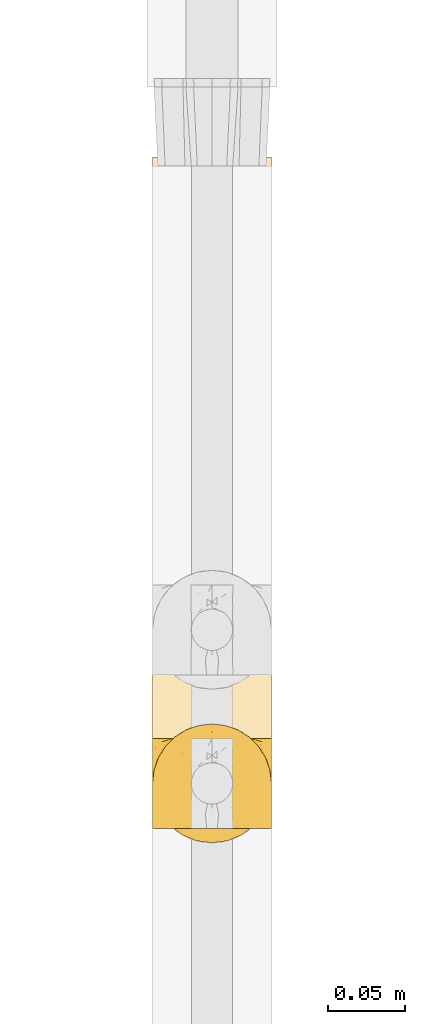
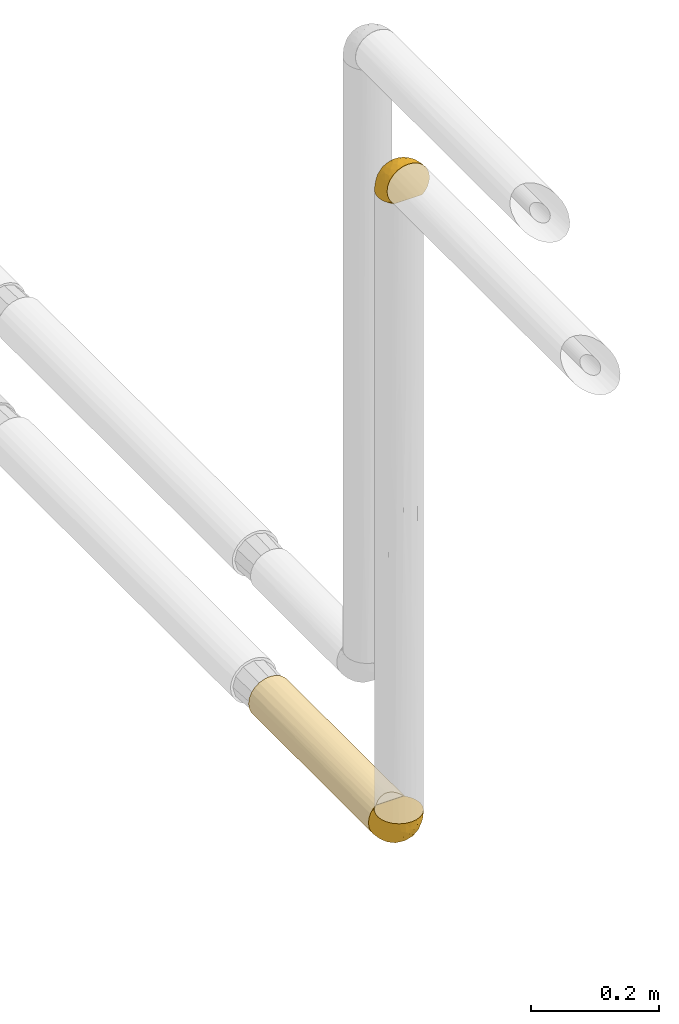
# One storey, part 105 of 827: 3 coverings.
"""IFC2X3 building model written with IfcOpenShell, lengths in millimetres."""

from ifc_helpers import new_model, entity, si_unit, converted_unit, derived_unit, direction, frame, origin, place, context, subcontext, project, spatial, faceted_brep, element, save


model = new_model("IFC2X3")

# Units and contexts
model_context = context("Model", 3, precision=0.01, world=origin(), true_north=direction((6.12303176911189e-17, 1.0)))
body_context = subcontext(model_context, "Body", "Model", "MODEL_VIEW")
ifc_project = project(units=[si_unit("LENGTHUNIT", "METRE", prefix="MILLI"), si_unit("AREAUNIT", "SQUARE_METRE"), si_unit("VOLUMEUNIT", "CUBIC_METRE"), converted_unit("PLANEANGLEUNIT", "DEGREE", entity("IfcRatioMeasure", 0.0174532925199433), si_unit("PLANEANGLEUNIT", "RADIAN"), dimensions=[0, 0, 0, 0, 0, 0, 0]), si_unit("MASSUNIT", "GRAM", prefix="KILO"), derived_unit("MASSDENSITYUNIT", [(si_unit("MASSUNIT", "GRAM", prefix="KILO"), 1), (si_unit("LENGTHUNIT", "METRE"), -3)]), derived_unit("MOMENTOFINERTIAUNIT", [(si_unit("LENGTHUNIT", "METRE"), 4)]), si_unit("TIMEUNIT", "SECOND"), si_unit("FREQUENCYUNIT", "HERTZ"), si_unit("THERMODYNAMICTEMPERATUREUNIT", "DEGREE_CELSIUS"), derived_unit("THERMALTRANSMITTANCEUNIT", [(si_unit("MASSUNIT", "GRAM", prefix="KILO"), 1), (si_unit("THERMODYNAMICTEMPERATUREUNIT", "KELVIN"), -1), (si_unit("TIMEUNIT", "SECOND"), -3)]), derived_unit("VOLUMETRICFLOWRATEUNIT", [(si_unit("LENGTHUNIT", "METRE"), 3), (si_unit("TIMEUNIT", "SECOND"), -1)]), derived_unit("MASSFLOWRATEUNIT", [(si_unit("MASSUNIT", "GRAM", prefix="KILO"), 1), (si_unit("TIMEUNIT", "SECOND"), -1)]), derived_unit("ROTATIONALFREQUENCYUNIT", [(si_unit("TIMEUNIT", "SECOND"), -1)]), si_unit("ELECTRICCURRENTUNIT", "AMPERE"), si_unit("ELECTRICVOLTAGEUNIT", "VOLT"), si_unit("POWERUNIT", "WATT"), si_unit("FORCEUNIT", "NEWTON", prefix="KILO"), si_unit("ILLUMINANCEUNIT", "LUX"), si_unit("LUMINOUSFLUXUNIT", "LUMEN"), si_unit("LUMINOUSINTENSITYUNIT", "CANDELA"), derived_unit("USERDEFINED", [(si_unit("MASSUNIT", "GRAM", prefix="KILO"), -1), (si_unit("LENGTHUNIT", "METRE"), -2), (si_unit("TIMEUNIT", "SECOND"), 3), (si_unit("LUMINOUSFLUXUNIT", "LUMEN"), 1)]), derived_unit("LINEARVELOCITYUNIT", [(si_unit("LENGTHUNIT", "METRE"), 1), (si_unit("TIMEUNIT", "SECOND"), -1)]), si_unit("PRESSUREUNIT", "PASCAL"), derived_unit("USERDEFINED", [(si_unit("LENGTHUNIT", "METRE"), -2), (si_unit("MASSUNIT", "GRAM", prefix="KILO"), 1), (si_unit("TIMEUNIT", "SECOND"), -2)]), derived_unit("LINEARFORCEUNIT", [(si_unit("MASSUNIT", "GRAM", prefix="KILO"), 1), (si_unit("LENGTHUNIT", "METRE"), 1), (si_unit("TIMEUNIT", "SECOND"), -2), (si_unit("LENGTHUNIT", "METRE"), -1)]), derived_unit("PLANARFORCEUNIT", [(si_unit("MASSUNIT", "GRAM", prefix="KILO"), 1), (si_unit("LENGTHUNIT", "METRE"), 1), (si_unit("TIMEUNIT", "SECOND"), -2), (si_unit("LENGTHUNIT", "METRE"), -2)])], contexts=[model_context])

# Site, building, storey
site_placement = place(None, origin())
site = spatial("IfcSite", under=ifc_project, at=site_placement, CompositionType="ELEMENT")
building_placement = place(site_placement, origin())
building = spatial("IfcBuilding", under=site, at=building_placement, CompositionType="ELEMENT")
storey_placement = place(building_placement, frame((0.0, 0.0, 28200.0)))
storey = spatial("IfcBuildingStorey", under=building, at=storey_placement, Name="08", CompositionType="ELEMENT", Elevation=28200.0)

# Coverings
covering_1_placement = place(storey_placement, frame((19736.22, 10277.55, 2771.03)))
element("IfcCovering", 1, at=covering_1_placement, inside=storey, Name=":ADSK_", ObjectType=":ADSK_", PredefinedType="INSULATION", context=body_context, shape_type="Brep", body=[
    faceted_brep([(5.41, 47.38, 1.6), (9.99, 54.67, 1.6), (16.08, 60.76, 1.6), (23.37, 65.34, 1.6), (31.49, 68.18, 1.6), (40.05, 69.15, 1.6), (48.61, 68.18, 1.6), (56.73, 65.33, 1.6), (64.02, 60.75, 1.6), (70.11, 54.66, 1.6), (74.69, 47.37, 1.6), (77.53, 39.25, 1.6), (78.5, 30.7, 1.6), (77.63, 22.59, 1.6), (75.08, 14.86, 1.6), (70.97, 7.84, 1.6), (65.47, 1.85, 1.6), (63.27, 1.85, 1.6), (61.53, 1.85, 1.6), (59.57, 1.85, 1.6), (57.6, 1.85, 1.6), (55.63, 1.85, 1.6), (53.67, 1.85, 1.6), (51.7, 1.85, 1.6), (49.73, 1.85, 1.6), (47.54, 1.85, 1.6), (45.34, 1.85, 1.6), (43.15, 1.85, 1.6), (40.96, 1.85, 1.6), (38.76, 1.85, 1.6), (36.57, 1.85, 1.6), (34.37, 1.85, 1.6), (32.18, 1.85, 1.6), (29.98, 1.85, 1.6), (27.79, 1.85, 1.6), (25.6, 1.85, 1.6), (23.4, 1.85, 1.6), (21.21, 1.85, 1.6), (19.01, 1.85, 1.6), (16.82, 1.85, 1.6), (14.62, 1.85, 1.6), (9.12, 7.85, 1.6), (5.0, 14.88, 1.6), (2.46, 22.61, 1.6), (1.6, 30.7, 1.6), (2.56, 39.26, 1.6), (65.47, 1.6, 1.85), (70.97, 1.6, 7.85), (75.09, 1.6, 14.87), (77.63, 1.6, 22.6), (78.5, 1.6, 30.7), (77.19, 1.6, 40.65), (73.34, 1.6, 49.92), (67.23, 1.6, 57.88), (59.27, 1.6, 63.99), (50.0, 1.6, 67.84), (40.05, 1.6, 69.15), (30.09, 1.6, 67.84), (20.82, 1.6, 63.99), (12.86, 1.6, 57.88), (6.75, 1.6, 49.92), (2.91, 1.6, 40.65), (1.6, 1.6, 30.7), (2.46, 1.6, 22.6), (5.0, 1.6, 14.87), (9.12, 1.6, 7.85), (14.62, 1.6, 1.85), (16.82, 1.6, 1.85), (17.8, 1.6, 1.85), (19.39, 1.6, 1.85), (20.98, 1.6, 1.85), (22.57, 1.6, 1.85), (24.16, 1.6, 1.85), (25.75, 1.6, 1.85), (27.33, 1.6, 1.85), (28.92, 1.6, 1.85), (30.51, 1.6, 1.85), (32.1, 1.6, 1.85), (33.69, 1.6, 1.85), (35.28, 1.6, 1.85), (36.87, 1.6, 1.85), (38.46, 1.6, 1.85), (40.05, 1.6, 1.85), (41.63, 1.6, 1.85), (43.22, 1.6, 1.85), (44.81, 1.6, 1.85), (46.4, 1.6, 1.85), (47.99, 1.6, 1.85), (49.58, 1.6, 1.85), (51.17, 1.6, 1.85), (52.76, 1.6, 1.85), (54.72, 1.6, 1.85), (56.69, 1.6, 1.85), (58.88, 1.6, 1.85), (61.08, 1.6, 1.85), (63.27, 1.6, 1.85), (37.77, 1.78, 1.77), (36.07, 1.77, 1.78), (32.96, 1.78, 1.77), (31.36, 1.77, 1.77), (56.52, 1.79, 1.76), (54.96, 1.78, 1.77), (18.75, 1.76, 1.79), (58.07, 1.77, 1.78), (50.37, 1.77, 1.78), (23.36, 1.76, 1.78), (24.95, 1.77, 1.78), (42.43, 1.77, 1.78), (15.97, 1.8, 1.74), (51.96, 1.76, 1.78), (53.47, 1.77, 1.78), (48.63, 1.78, 1.77), (63.93, 1.77, 1.78), (40.93, 1.77, 1.78), (29.72, 1.76, 1.78), (62.4, 1.77, 1.77), (60.92, 1.78, 1.77), (17.31, 1.77, 1.77), (21.74, 1.77, 1.78), (34.56, 1.77, 1.78), (20.18, 1.78, 1.77), (14.62, 1.77, 1.77), (14.62, 1.8, 1.72), (14.62, 1.82, 1.66), (65.47, 1.77, 1.77), (65.47, 1.72, 1.8), (65.47, 1.66, 1.82), (59.5, 1.76, 1.79), (47.1, 1.77, 1.78), (45.61, 1.76, 1.79), (28.18, 1.77, 1.78), (14.62, 1.66, 1.82), (14.62, 1.72, 1.8), (26.61, 1.78, 1.76), (65.47, 1.82, 1.66), (65.47, 1.8, 1.72), (39.32, 1.77, 1.78), (44.12, 1.78, 1.77), (72.26, 3.72, 9.41), (76.57, 7.41, 17.65), (71.77, 6.13, 7.41), (78.5, 21.47, 21.47), (77.9, 19.34, 15.21), (78.5, 26.8, 16.15), (78.5, 8.87, 28.75), (75.52, 9.2, 13.67), (76.13, 12.79, 12.79), (77.81, 14.62, 19.18), (78.5, 7.34, 29.16), (72.4, 5.33, 9.04), (76.56, 17.64, 7.41), (71.77, 7.7, 5.74), (72.25, 9.41, 3.72), (78.5, 28.75, 8.87), (78.5, 16.15, 26.8), (75.75, 14.14, 9.53), (78.5, 29.16, 7.34), (50.46, 57.02, 37.63), (52.75, 64.92, 17.92), (40.05, 64.0, 27.45), (77.7, 11.92, 37.01), (77.66, 19.16, 34.22), (71.02, 28.65, 45.87), (63.45, 24.62, 56.57), (70.55, 15.19, 52.31), (75.57, 18.36, 42.07), (75.57, 9.2, 44.74), (72.61, 46.98, 21.49), (72.61, 50.24, 11.02), (67.24, 56.1, 15.64), (77.74, 28.97, 26.02), (57.43, 54.46, 36.59), (47.19, 21.34, 65.49), (54.76, 18.4, 63.99), (40.05, 66.44, 15.2), (63.45, 12.07, 60.27), (60.1, 45.49, 45.25), (63.72, 50.57, 35.21), (76.83, 36.04, 22.52), (76.34, 42.07, 12.03), (60.51, 62.12, 13.32), (72.59, 37.37, 35.9), (76.05, 29.39, 33.87), (66.15, 53.59, 25.73), (60.51, 58.06, 26.34), (51.88, 49.27, 46.78), (55.34, 29.63, 59.54), (48.67, 33.21, 60.18), (53.89, 40.1, 53.93), (46.73, 44.08, 53.36), (40.05, 49.36, 49.36), (40.05, 56.68, 38.4), (40.05, 15.2, 66.44), (63.95, 35.57, 50.09), (67.24, 41.7, 41.08), (69.62, 46.4, 31.14), (73.6, 41.41, 28.19), (40.05, 27.45, 64.0), (40.05, 38.4, 56.68), (4.52, 12.99, 43.9), (32.72, 21.33, 65.46), (27.18, 42.89, 52.22), (29.63, 57.04, 37.61), (12.86, 56.11, 15.64), (19.59, 62.13, 13.31), (9.54, 21.89, 50.02), (16.64, 16.62, 59.28), (17.48, 32.9, 53.05), (7.49, 46.99, 21.48), (7.49, 50.25, 11.01), (3.75, 42.08, 12.03), (20.75, 49.91, 41.02), (2.33, 15.6, 35.39), (1.6, 16.15, 26.8), (1.6, 8.87, 28.75), (1.6, 29.16, 7.34), (26.94, 13.16, 65.81), (9.54, 10.83, 53.28), (31.21, 33.8, 59.8), (25.33, 25.02, 61.82), (27.35, 64.92, 17.91), (8.17, 32.83, 41.4), (4.3, 20.56, 40.48), (19.59, 58.07, 26.34), (2.23, 21.46, 31.68), (2.45, 28.1, 27.68), (1.6, 26.8, 16.15), (1.6, 21.47, 21.47), (12.86, 51.29, 28.05), (3.27, 36.04, 22.54), (1.6, 28.75, 8.87), (2.29, 8.45, 37.3), (12.86, 41.73, 41.07), (6.89, 39.27, 32.24), (12.43, 33.56, 47.4), (4.1, 27.29, 35.77), (3.53, 7.41, 17.65), (6.88, 3.51, 11.06), (8.16, 4.68, 8.55), (9.02, 5.52, 6.63), (5.0, 8.75, 12.77), (3.96, 12.79, 12.79), (3.52, 17.65, 7.41), (2.4, 13.9, 18.97), (7.83, 9.42, 3.72), (8.32, 7.68, 5.76), (2.19, 19.33, 15.21), (4.34, 14.13, 9.52)], [[[0, 1, 2, 3, 4, 5, 6, 7, 8, 9, 10, 11, 12, 13, 14, 15, 16, 17, 18, 19, 20, 21, 22, 23, 24, 25, 26, 27, 28, 29, 30, 31, 32, 33, 34, 35, 36, 37, 38, 39, 40, 41, 42, 43, 44, 45]], [[46, 47, 48, 49, 50, 51, 52, 53, 54, 55, 56, 57, 58, 59, 60, 61, 62, 63, 64, 65, 66, 67, 68, 69, 70, 71, 72, 73, 74, 75, 76, 77, 78, 79, 80, 81, 82, 83, 84, 85, 86, 87, 88, 89, 90, 91, 92, 93, 94, 95]], [[96, 97, 30]], [[98, 77, 99]], [[100, 101, 21]], [[69, 68, 102]], [[20, 19, 103]], [[24, 23, 104]], [[20, 103, 100]], [[72, 105, 106]], [[84, 83, 107]], [[89, 88, 104]], [[108, 67, 66]], [[109, 110, 90]], [[111, 25, 24]], [[112, 17, 16]], [[82, 113, 83]], [[109, 23, 22]], [[114, 76, 75]], [[105, 36, 106]], [[104, 111, 24]], [[18, 115, 116]], [[97, 96, 80]], [[67, 108, 117]], [[105, 71, 118]], [[31, 97, 119]], [[102, 120, 69]], [[108, 121, 122, 123, 40]], [[112, 95, 115]], [[17, 115, 18]], [[94, 116, 115]], [[117, 68, 67]], [[38, 117, 39]], [[112, 124, 125, 126, 46]], [[17, 112, 115]], [[70, 120, 118]], [[39, 117, 108]], [[120, 38, 37]], [[120, 37, 118]], [[120, 70, 69]], [[116, 94, 127]], [[128, 86, 129]], [[117, 38, 102]], [[74, 130, 75]], [[99, 33, 32]], [[115, 95, 94]], [[39, 108, 40]], [[108, 66, 131, 132, 121]], [[105, 72, 71]], [[118, 37, 36]], [[71, 70, 118]], [[35, 106, 36]], [[36, 105, 118]], [[35, 133, 106]], [[74, 73, 133]], [[106, 133, 73]], [[99, 114, 33]], [[133, 35, 34]], [[73, 72, 106]], [[95, 112, 46]], [[112, 16, 134, 135, 124]], [[130, 114, 75]], [[99, 76, 114]], [[114, 130, 33]], [[34, 33, 130]], [[78, 77, 98]], [[98, 119, 78]], [[130, 133, 34]], [[133, 130, 74]], [[79, 97, 80]], [[98, 99, 32]], [[98, 32, 31]], [[77, 76, 99]], [[97, 79, 119]], [[136, 96, 29]], [[30, 97, 31]], [[136, 29, 28]], [[81, 80, 96]], [[29, 96, 30]], [[31, 119, 98]], [[119, 79, 78]], [[96, 136, 81]], [[82, 81, 136]], [[113, 107, 83]], [[84, 107, 137]], [[107, 27, 137]], [[113, 28, 107]], [[27, 107, 28]], [[85, 84, 137]], [[137, 27, 26]], [[113, 136, 28]], [[136, 113, 82]], [[109, 89, 104]], [[86, 85, 129]], [[89, 109, 90]], [[111, 87, 128]], [[26, 129, 137]], [[88, 111, 104]], [[25, 111, 128]], [[22, 110, 109]], [[23, 109, 104]], [[110, 91, 90]], [[100, 92, 101]], [[110, 22, 101]], [[91, 110, 101]], [[116, 19, 18]], [[111, 88, 87]], [[127, 103, 19]], [[25, 128, 26]], [[86, 128, 87]], [[128, 129, 26]], [[137, 129, 85]], [[120, 102, 38]], [[117, 102, 68]], [[91, 101, 92]], [[21, 101, 22]], [[93, 92, 103]], [[100, 21, 20]], [[100, 103, 92]], [[127, 93, 103]], [[93, 127, 94]], [[116, 127, 19]], [[126, 138, 47]], [[48, 138, 139]], [[140, 125, 124]], [[141, 142, 143]], [[144, 49, 139]], [[145, 140, 146]], [[48, 139, 49]], [[139, 145, 147]], [[49, 144, 148, 50]], [[126, 125, 149]], [[14, 13, 150]], [[151, 146, 140]], [[149, 140, 145]], [[152, 151, 135]], [[152, 14, 150]], [[16, 15, 134]], [[13, 153, 150]], [[124, 151, 140]], [[141, 147, 142]], [[14, 152, 15]], [[15, 152, 134]], [[47, 46, 126]], [[139, 154, 144]], [[138, 48, 47]], [[125, 140, 149]], [[135, 134, 152]], [[146, 155, 142]], [[145, 146, 147]], [[149, 139, 138]], [[147, 141, 154]], [[147, 146, 142]], [[139, 147, 154]], [[139, 149, 145]], [[149, 138, 126]], [[155, 146, 151]], [[150, 143, 142]], [[152, 155, 151]], [[150, 142, 155]], [[13, 12, 156, 153]], [[153, 143, 150]], [[152, 150, 155]], [[151, 124, 135]], [[157, 158, 159]], [[160, 154, 161]], [[162, 163, 164]], [[165, 166, 160]], [[167, 168, 169]], [[141, 170, 161]], [[156, 12, 11]], [[158, 157, 171]], [[172, 55, 173]], [[158, 6, 174]], [[175, 54, 53]], [[52, 166, 164]], [[52, 164, 53]], [[54, 175, 173]], [[166, 52, 51]], [[176, 177, 171]], [[178, 143, 179]], [[156, 11, 179]], [[8, 7, 180]], [[169, 9, 8]], [[179, 143, 153, 156]], [[179, 11, 10]], [[168, 179, 10]], [[181, 162, 182]], [[179, 167, 178]], [[183, 184, 177]], [[183, 169, 184]], [[176, 171, 185]], [[172, 186, 187]], [[158, 7, 6]], [[159, 158, 174]], [[184, 180, 158]], [[54, 173, 55]], [[180, 169, 8]], [[188, 189, 187]], [[9, 168, 10]], [[186, 188, 187]], [[190, 157, 159, 191]], [[55, 172, 192]], [[176, 193, 194]], [[161, 170, 182]], [[162, 164, 165]], [[175, 164, 163]], [[51, 50, 148]], [[167, 195, 196]], [[178, 182, 170]], [[6, 5, 174]], [[158, 180, 7]], [[169, 180, 184]], [[169, 168, 9]], [[179, 168, 167]], [[182, 162, 165]], [[162, 194, 193]], [[161, 165, 160]], [[195, 181, 196]], [[192, 172, 197]], [[192, 56, 55]], [[189, 190, 198]], [[198, 197, 187]], [[172, 187, 197]], [[185, 189, 188]], [[198, 187, 189]], [[186, 172, 173]], [[173, 163, 186]], [[193, 186, 163]], [[176, 185, 188]], [[185, 157, 190]], [[188, 186, 193]], [[177, 176, 194]], [[188, 193, 176]], [[162, 193, 163]], [[195, 177, 194]], [[171, 177, 184]], [[181, 195, 194]], [[183, 167, 169]], [[162, 181, 194]], [[196, 182, 178]], [[158, 171, 184]], [[171, 157, 185]], [[177, 195, 183]], [[167, 183, 195]], [[182, 196, 181]], [[178, 170, 143]], [[178, 167, 196]], [[164, 175, 53]], [[173, 175, 163]], [[160, 51, 148]], [[164, 166, 165]], [[51, 160, 166]], [[160, 148, 144, 154]], [[141, 161, 154]], [[182, 165, 161]], [[190, 189, 185]], [[143, 170, 141]], [[60, 199, 61]], [[197, 200, 192]], [[201, 190, 202]], [[200, 57, 192]], [[203, 204, 2]], [[205, 206, 207]], [[208, 209, 210]], [[211, 207, 201]], [[212, 213, 214]], [[45, 215, 210]], [[216, 206, 58]], [[45, 44, 215]], [[59, 217, 60]], [[60, 217, 199]], [[0, 45, 210]], [[218, 201, 219]], [[202, 159, 220]], [[205, 221, 222]], [[223, 204, 203]], [[1, 203, 2]], [[57, 200, 216]], [[220, 3, 204]], [[220, 174, 4]], [[1, 0, 209]], [[212, 224, 213]], [[225, 226, 227]], [[228, 223, 203]], [[208, 210, 229]], [[210, 226, 229]], [[3, 220, 4]], [[58, 206, 59]], [[209, 203, 1]], [[202, 220, 223]], [[228, 203, 208]], [[202, 211, 201]], [[3, 2, 204]], [[202, 190, 191, 159]], [[210, 215, 230, 226]], [[199, 212, 231]], [[232, 233, 221]], [[233, 208, 229]], [[207, 206, 219]], [[217, 206, 205]], [[227, 224, 225]], [[233, 232, 228]], [[201, 207, 219]], [[234, 232, 221]], [[218, 219, 200]], [[202, 223, 211]], [[174, 220, 159]], [[174, 5, 4]], [[61, 231, 62]], [[220, 204, 223]], [[210, 209, 0]], [[203, 209, 208]], [[225, 233, 229]], [[224, 227, 213]], [[221, 233, 235]], [[57, 56, 192]], [[198, 218, 197]], [[200, 219, 216]], [[201, 198, 190]], [[197, 218, 200]], [[198, 201, 218]], [[206, 216, 219]], [[58, 57, 216]], [[231, 212, 214]], [[222, 212, 199]], [[228, 211, 223]], [[207, 211, 232]], [[62, 231, 214]], [[199, 231, 61]], [[233, 228, 208]], [[211, 228, 232]], [[222, 221, 235]], [[234, 205, 207]], [[206, 217, 59]], [[199, 217, 205]], [[205, 222, 199]], [[224, 222, 235]], [[222, 224, 212]], [[224, 235, 225]], [[233, 225, 235]], [[226, 225, 229]], [[205, 234, 221]], [[207, 232, 234]], [[63, 214, 236]], [[214, 213, 236]], [[214, 63, 62]], [[237, 236, 238]], [[238, 132, 131]], [[236, 237, 64]], [[239, 240, 241]], [[63, 236, 64]], [[131, 66, 65]], [[237, 131, 65]], [[242, 230, 43]], [[237, 65, 64]], [[239, 121, 132]], [[42, 242, 43]], [[241, 240, 243]], [[41, 123, 244]], [[43, 230, 215, 44]], [[244, 122, 245]], [[227, 246, 243]], [[241, 247, 245]], [[121, 239, 245]], [[41, 40, 123]], [[132, 238, 239]], [[244, 42, 41]], [[131, 237, 238]], [[240, 239, 238]], [[245, 239, 241]], [[247, 241, 246]], [[247, 244, 245]], [[238, 236, 240]], [[243, 236, 213]], [[236, 243, 240]], [[227, 226, 246]], [[243, 213, 227]], [[242, 246, 226]], [[243, 246, 241]], [[246, 242, 247]], [[244, 247, 242]], [[242, 226, 230]], [[42, 244, 242]], [[122, 244, 123]], [[122, 121, 245]]]),
])
covering_2_placement = place(storey_placement, frame((19736.27, 10335.75, 1518.17)))
element("IfcCovering", 2, at=covering_2_placement, inside=storey, Name=":ADSK_", ObjectType=":ADSK_", PredefinedType="INSULATION", context=body_context, shape_type="Brep", body=[
    faceted_brep([(20.8, 1.6, 6.74), (30.06, 1.6, 2.9), (40.0, 1.6, 1.6), (49.93, 1.6, 2.9), (59.2, 1.6, 6.74), (67.15, 1.6, 12.84), (73.25, 1.6, 20.8), (77.09, 1.6, 30.06), (78.4, 1.6, 40.0), (77.51, 1.6, 48.2), (74.9, 1.6, 56.01), (70.68, 1.6, 63.08), (65.05, 1.6, 69.1), (14.94, 1.6, 69.1), (9.31, 1.6, 63.08), (5.09, 1.6, 56.01), (2.48, 1.6, 48.2), (1.6, 1.6, 40.0), (2.9, 1.6, 30.06), (6.74, 1.6, 20.8), (12.84, 1.6, 12.84), (20.8, 377.5, 6.74), (12.84, 377.5, 12.84), (6.74, 377.5, 20.8), (2.9, 377.5, 30.06), (1.6, 377.5, 40.0), (2.9, 377.5, 49.93), (6.74, 377.5, 59.2), (12.84, 377.5, 67.15), (20.8, 377.5, 73.25), (30.06, 377.5, 77.09), (40.0, 377.5, 78.4), (49.93, 377.5, 77.09), (59.2, 377.5, 73.25), (67.15, 377.5, 67.15), (73.25, 377.5, 59.2), (77.09, 377.5, 49.93), (78.4, 377.5, 40.0), (77.09, 377.5, 30.06), (73.25, 377.5, 20.8), (67.15, 377.5, 12.84), (59.2, 377.5, 6.74), (49.93, 377.5, 2.9), (40.0, 377.5, 1.6), (30.06, 377.5, 2.9), (53.36, 8.5, 76.0), (46.78, 10.29, 77.79), (40.0, 10.9, 78.4), (59.51, 5.57, 73.07), (33.21, 10.29, 77.79), (26.63, 8.5, 76.0), (20.48, 5.57, 73.07)], [[[0, 1, 2, 3, 4, 5, 6, 7, 8, 9, 10, 11, 12, 13, 14, 15, 16, 17, 18, 19, 20]], [[21, 22, 23, 24, 25, 26, 27, 28, 29, 30, 31, 32, 33, 34, 35, 36, 37, 38, 39, 40, 41, 42, 43, 44]], [[24, 23, 19, 18]], [[25, 24, 18, 17]], [[20, 19, 23, 22]], [[1, 0, 21, 44]], [[2, 1, 44, 43]], [[22, 21, 0, 20]], [[3, 2, 43, 42]], [[4, 3, 42, 41]], [[41, 40, 5, 4]], [[7, 6, 39, 38]], [[8, 7, 38, 37]], [[40, 39, 6, 5]], [[9, 37, 36]], [[10, 36, 35]], [[11, 35, 34]], [[8, 37, 9]], [[9, 36, 10]], [[35, 11, 10]], [[34, 12, 11]], [[45, 33, 32]], [[32, 31, 46]], [[47, 46, 31]], [[48, 12, 33]], [[46, 45, 32]], [[48, 33, 45]], [[33, 12, 34]], [[49, 47, 31]], [[49, 31, 30]], [[50, 30, 29]], [[50, 49, 30]], [[13, 51, 29]], [[50, 29, 51]], [[29, 28, 13]], [[14, 28, 27]], [[15, 27, 26]], [[16, 26, 25]], [[14, 27, 15]], [[15, 26, 16]], [[25, 17, 16]], [[28, 14, 13]], [[48, 45, 46, 47, 49, 50, 51, 13, 12]]]),
])
covering_3_placement = place(storey_placement, frame((19736.22, 10268.2, 1518.12)))
element("IfcCovering", 3, at=covering_3_placement, inside=storey, Name=":ADSK_", ObjectType=":ADSK_", PredefinedType="INSULATION", context=body_context, shape_type="Brep", body=[
    faceted_brep([(74.68, 69.15, 23.36), (70.1, 69.15, 16.07), (64.01, 69.15, 9.98), (56.72, 69.15, 5.4), (48.6, 69.15, 2.56), (40.05, 69.15, 1.6), (31.49, 69.15, 2.56), (23.36, 69.15, 5.41), (16.07, 69.15, 9.99), (9.98, 69.15, 16.08), (5.4, 69.15, 23.37), (2.56, 69.15, 31.49), (1.6, 69.15, 40.05), (2.46, 69.15, 48.15), (5.01, 69.15, 55.88), (9.13, 69.15, 62.9), (14.62, 69.15, 68.89), (16.82, 69.15, 68.89), (18.56, 69.15, 68.89), (20.52, 69.15, 68.89), (22.49, 69.15, 68.89), (24.46, 69.15, 68.89), (26.42, 69.15, 68.89), (28.39, 69.15, 68.89), (30.36, 69.15, 68.89), (32.55, 69.15, 68.89), (34.75, 69.15, 68.89), (36.94, 69.15, 68.89), (39.13, 69.15, 68.89), (41.33, 69.15, 68.89), (43.52, 69.15, 68.89), (45.72, 69.15, 68.89), (47.91, 69.15, 68.89), (50.11, 69.15, 68.89), (52.3, 69.15, 68.89), (54.49, 69.15, 68.89), (56.69, 69.15, 68.89), (58.88, 69.15, 68.89), (61.08, 69.15, 68.89), (63.27, 69.15, 68.89), (65.47, 69.15, 68.89), (70.97, 69.15, 62.89), (75.09, 69.15, 55.86), (77.64, 69.15, 48.13), (78.5, 69.15, 40.05), (77.53, 69.15, 31.49), (14.62, 68.89, 69.15), (9.12, 62.89, 69.15), (5.0, 55.87, 69.15), (2.46, 48.14, 69.15), (1.6, 40.05, 69.15), (2.91, 30.09, 69.15), (6.75, 20.82, 69.15), (12.86, 12.86, 69.15), (20.82, 6.75, 69.15), (30.09, 2.91, 69.15), (40.05, 1.6, 69.15), (50.0, 2.91, 69.15), (59.27, 6.75, 69.15), (67.23, 12.86, 69.15), (73.34, 20.82, 69.15), (77.19, 30.09, 69.15), (78.5, 40.05, 69.15), (77.63, 48.14, 69.15), (75.09, 55.87, 69.15), (70.97, 62.89, 69.15), (65.47, 68.89, 69.15), (63.27, 68.89, 69.15), (62.29, 68.89, 69.15), (60.7, 68.89, 69.15), (59.11, 68.89, 69.15), (57.52, 68.89, 69.15), (55.93, 68.89, 69.15), (54.34, 68.89, 69.15), (52.76, 68.89, 69.15), (51.17, 68.89, 69.15), (49.58, 68.89, 69.15), (47.99, 68.89, 69.15), (46.4, 68.89, 69.15), (44.81, 68.89, 69.15), (43.22, 68.89, 69.15), (41.63, 68.89, 69.15), (40.05, 68.89, 69.15), (38.46, 68.89, 69.15), (36.87, 68.89, 69.15), (35.28, 68.89, 69.15), (33.69, 68.89, 69.15), (32.1, 68.89, 69.15), (30.51, 68.89, 69.15), (28.92, 68.89, 69.15), (27.33, 68.89, 69.15), (25.37, 68.89, 69.15), (23.4, 68.89, 69.15), (21.21, 68.89, 69.15), (19.01, 68.89, 69.15), (16.82, 68.89, 69.15), (42.32, 68.97, 68.96), (44.02, 68.96, 68.97), (47.13, 68.97, 68.97), (48.74, 68.97, 68.97), (23.57, 68.98, 68.95), (25.13, 68.97, 68.96), (61.34, 68.96, 68.98), (22.02, 68.96, 68.97), (29.72, 68.96, 68.97), (56.73, 68.96, 68.98), (55.14, 68.96, 68.97), (37.66, 68.96, 68.97), (64.12, 69.0, 68.94), (28.13, 68.96, 68.98), (26.62, 68.96, 68.98), (31.46, 68.97, 68.96), (16.16, 68.96, 68.97), (39.16, 68.96, 68.98), (50.37, 68.96, 68.98), (17.69, 68.97, 68.97), (19.17, 68.97, 68.96), (62.78, 68.97, 68.97), (58.35, 68.96, 68.97), (45.53, 68.96, 68.98), (59.91, 68.97, 68.96), (65.47, 68.97, 68.97), (65.47, 69.02, 68.94), (65.47, 69.08, 68.92), (14.62, 68.97, 68.97), (14.62, 68.94, 69.02), (14.62, 68.92, 69.08), (20.59, 68.96, 68.98), (32.99, 68.96, 68.97), (34.48, 68.95, 68.98), (51.91, 68.96, 68.97), (65.47, 68.92, 69.08), (65.47, 68.94, 69.02), (53.48, 68.98, 68.96), (14.62, 69.08, 68.92), (14.62, 69.02, 68.94), (40.77, 68.96, 68.97), (35.97, 68.97, 68.96), (7.84, 61.33, 67.02), (3.53, 53.1, 63.33), (8.32, 63.33, 64.61), (2.19, 55.53, 51.4), (3.53, 63.33, 53.1), (1.6, 54.6, 43.94), (1.6, 41.99, 61.87), (4.57, 57.07, 61.54), (3.96, 57.95, 57.95), (2.28, 51.56, 56.12), (1.6, 41.58, 63.4), (7.69, 61.7, 65.41), (8.32, 65.0, 63.04), (7.84, 67.02, 61.33), (1.6, 61.87, 41.99), (1.6, 49.27, 49.27), (1.6, 43.94, 54.6), (4.34, 61.21, 56.6), (1.6, 63.4, 41.58), (29.63, 33.11, 13.72), (27.34, 52.82, 5.82), (40.05, 43.3, 6.74), (2.39, 33.73, 58.82), (2.43, 36.52, 51.58), (9.07, 24.87, 42.09), (16.64, 14.17, 46.12), (9.54, 18.43, 55.56), (4.52, 28.67, 52.38), (4.52, 26.0, 61.54), (7.49, 49.25, 23.76), (7.49, 59.72, 20.5), (12.85, 55.1, 14.64), (2.35, 44.72, 41.77), (22.66, 34.15, 16.28), (32.9, 5.25, 49.4), (25.33, 6.75, 52.34), (40.05, 55.54, 4.3), (16.64, 10.47, 58.67), (19.99, 25.49, 25.26), (16.37, 35.53, 20.17), (3.26, 48.22, 34.7), (3.75, 58.71, 28.67), (19.58, 57.42, 8.62), (7.5, 34.84, 33.37), (4.04, 36.87, 41.35), (13.94, 45.01, 17.15), (19.58, 44.4, 12.68), (28.21, 23.96, 21.47), (24.75, 11.2, 41.11), (31.42, 10.56, 37.53), (26.2, 16.81, 30.64), (33.36, 17.38, 26.66), (40.05, 21.38, 21.38), (40.05, 32.34, 14.06), (40.05, 4.3, 55.54), (16.14, 20.65, 35.17), (12.85, 29.66, 29.04), (10.47, 39.6, 24.34), (6.49, 42.55, 29.33), (40.05, 6.74, 43.3), (40.05, 14.06, 32.34), (75.57, 26.84, 57.75), (47.37, 5.28, 49.41), (52.91, 18.52, 27.85), (50.46, 33.13, 13.7), (67.23, 55.1, 14.63), (60.5, 57.43, 8.61), (70.55, 20.72, 48.85), (63.45, 11.46, 54.13), (62.61, 17.69, 37.84), (72.6, 49.26, 23.75), (72.6, 59.73, 20.49), (76.34, 58.71, 28.66), (59.34, 29.72, 20.83), (77.76, 35.35, 55.15), (78.5, 43.94, 54.6), (78.5, 41.99, 61.87), (78.5, 63.4, 41.58), (53.16, 4.93, 57.58), (70.55, 17.46, 59.91), (48.88, 10.94, 36.94), (54.76, 8.92, 45.72), (52.74, 52.83, 5.82), (71.93, 29.34, 37.91), (75.79, 30.26, 50.18), (60.5, 44.4, 12.67), (77.86, 39.06, 49.29), (77.64, 43.06, 42.64), (78.5, 54.6, 43.94), (78.5, 49.27, 49.27), (67.23, 42.69, 19.45), (76.82, 48.2, 34.7), (78.5, 61.87, 41.99), (77.8, 33.44, 62.29), (67.23, 29.67, 29.01), (73.2, 38.5, 31.47), (67.66, 23.35, 37.18), (75.99, 34.97, 43.45), (76.57, 53.1, 63.33), (73.21, 59.68, 67.23), (71.93, 62.19, 66.07), (71.07, 64.11, 65.22), (75.09, 57.97, 61.99), (76.13, 57.95, 57.95), (76.57, 63.33, 53.09), (77.69, 51.77, 56.84), (72.26, 67.02, 61.33), (71.77, 64.98, 63.06), (77.9, 55.53, 51.41), (75.75, 61.22, 56.61)], [[[0, 1, 2, 3, 4, 5, 6, 7, 8, 9, 10, 11, 12, 13, 14, 15, 16, 17, 18, 19, 20, 21, 22, 23, 24, 25, 26, 27, 28, 29, 30, 31, 32, 33, 34, 35, 36, 37, 38, 39, 40, 41, 42, 43, 44, 45]], [[46, 47, 48, 49, 50, 51, 52, 53, 54, 55, 56, 57, 58, 59, 60, 61, 62, 63, 64, 65, 66, 67, 68, 69, 70, 71, 72, 73, 74, 75, 76, 77, 78, 79, 80, 81, 82, 83, 84, 85, 86, 87, 88, 89, 90, 91, 92, 93, 94, 95]], [[96, 97, 30]], [[98, 77, 99]], [[100, 101, 21]], [[69, 68, 102]], [[20, 19, 103]], [[24, 23, 104]], [[20, 103, 100]], [[72, 105, 106]], [[84, 83, 107]], [[89, 88, 104]], [[108, 67, 66]], [[109, 110, 90]], [[111, 25, 24]], [[112, 17, 16]], [[82, 113, 83]], [[109, 23, 22]], [[114, 76, 75]], [[105, 36, 106]], [[104, 111, 24]], [[18, 115, 116]], [[97, 96, 80]], [[67, 108, 117]], [[105, 71, 118]], [[31, 97, 119]], [[102, 120, 69]], [[108, 121, 122, 123, 40]], [[112, 95, 115]], [[17, 115, 18]], [[94, 116, 115]], [[117, 68, 67]], [[38, 117, 39]], [[112, 124, 125, 126, 46]], [[17, 112, 115]], [[70, 120, 118]], [[39, 117, 108]], [[120, 38, 37]], [[120, 37, 118]], [[120, 70, 69]], [[116, 94, 127]], [[128, 86, 129]], [[117, 38, 102]], [[74, 130, 75]], [[99, 33, 32]], [[115, 95, 94]], [[39, 108, 40]], [[108, 66, 131, 132, 121]], [[105, 72, 71]], [[118, 37, 36]], [[71, 70, 118]], [[35, 106, 36]], [[36, 105, 118]], [[35, 133, 106]], [[74, 73, 133]], [[106, 133, 73]], [[99, 114, 33]], [[133, 35, 34]], [[73, 72, 106]], [[95, 112, 46]], [[112, 16, 134, 135, 124]], [[130, 114, 75]], [[99, 76, 114]], [[114, 130, 33]], [[34, 33, 130]], [[78, 77, 98]], [[98, 119, 78]], [[130, 133, 34]], [[133, 130, 74]], [[79, 97, 80]], [[98, 99, 32]], [[98, 32, 31]], [[77, 76, 99]], [[97, 79, 119]], [[136, 96, 29]], [[30, 97, 31]], [[136, 29, 28]], [[81, 80, 96]], [[29, 96, 30]], [[31, 119, 98]], [[119, 79, 78]], [[96, 136, 81]], [[82, 81, 136]], [[113, 107, 83]], [[84, 107, 137]], [[107, 27, 137]], [[113, 28, 107]], [[27, 107, 28]], [[85, 84, 137]], [[137, 27, 26]], [[113, 136, 28]], [[136, 113, 82]], [[109, 89, 104]], [[86, 85, 129]], [[89, 109, 90]], [[111, 87, 128]], [[26, 129, 137]], [[88, 111, 104]], [[25, 111, 128]], [[22, 110, 109]], [[23, 109, 104]], [[110, 91, 90]], [[100, 92, 101]], [[110, 22, 101]], [[91, 110, 101]], [[116, 19, 18]], [[111, 88, 87]], [[127, 103, 19]], [[25, 128, 26]], [[86, 128, 87]], [[128, 129, 26]], [[137, 129, 85]], [[120, 102, 38]], [[117, 102, 68]], [[91, 101, 92]], [[21, 101, 22]], [[93, 92, 103]], [[100, 21, 20]], [[100, 103, 92]], [[127, 93, 103]], [[93, 127, 94]], [[116, 127, 19]], [[126, 138, 47]], [[48, 138, 139]], [[140, 125, 124]], [[141, 142, 143]], [[144, 49, 139]], [[145, 140, 146]], [[48, 139, 49]], [[139, 145, 147]], [[49, 144, 148, 50]], [[126, 125, 149]], [[14, 13, 142]], [[150, 146, 140]], [[149, 140, 145]], [[151, 150, 135]], [[151, 14, 142]], [[16, 15, 134]], [[13, 152, 142]], [[124, 150, 140]], [[141, 143, 153]], [[14, 151, 15]], [[15, 151, 134]], [[47, 46, 126]], [[139, 154, 144]], [[138, 48, 47]], [[125, 140, 149]], [[135, 134, 151]], [[146, 155, 141]], [[145, 146, 147]], [[149, 139, 138]], [[147, 153, 154]], [[147, 146, 141]], [[139, 147, 154]], [[139, 149, 145]], [[149, 138, 126]], [[147, 141, 153]], [[146, 150, 155]], [[151, 155, 150]], [[142, 141, 155]], [[13, 12, 156, 152]], [[152, 143, 142]], [[151, 142, 155]], [[150, 124, 135]], [[157, 158, 159]], [[160, 154, 161]], [[162, 163, 164]], [[165, 166, 160]], [[167, 168, 169]], [[153, 170, 161]], [[156, 12, 11]], [[158, 157, 171]], [[172, 55, 173]], [[158, 6, 174]], [[175, 54, 53]], [[52, 166, 164]], [[52, 164, 53]], [[54, 175, 173]], [[166, 52, 51]], [[176, 177, 171]], [[178, 143, 179]], [[156, 11, 179]], [[8, 7, 180]], [[169, 9, 8]], [[179, 143, 152, 156]], [[179, 11, 10]], [[168, 179, 10]], [[181, 162, 182]], [[179, 167, 178]], [[183, 184, 177]], [[183, 169, 184]], [[176, 171, 185]], [[172, 186, 187]], [[158, 7, 6]], [[159, 158, 174]], [[184, 180, 158]], [[54, 173, 55]], [[180, 169, 8]], [[188, 189, 187]], [[9, 168, 10]], [[186, 188, 187]], [[190, 157, 159, 191]], [[55, 172, 192]], [[176, 193, 194]], [[161, 170, 182]], [[162, 164, 165]], [[175, 164, 163]], [[51, 50, 148]], [[167, 195, 196]], [[178, 182, 170]], [[6, 5, 174]], [[158, 180, 7]], [[169, 180, 184]], [[169, 168, 9]], [[179, 168, 167]], [[182, 162, 165]], [[162, 194, 193]], [[161, 165, 160]], [[195, 181, 196]], [[192, 172, 197]], [[192, 56, 55]], [[189, 190, 198]], [[198, 197, 187]], [[172, 187, 197]], [[185, 189, 188]], [[198, 187, 189]], [[186, 172, 173]], [[173, 163, 186]], [[193, 186, 163]], [[176, 185, 188]], [[185, 157, 190]], [[188, 186, 193]], [[177, 176, 194]], [[188, 193, 176]], [[162, 193, 163]], [[195, 177, 194]], [[171, 177, 184]], [[181, 195, 194]], [[183, 167, 169]], [[162, 181, 194]], [[196, 182, 178]], [[158, 171, 184]], [[171, 157, 185]], [[177, 195, 183]], [[167, 183, 195]], [[182, 196, 181]], [[178, 170, 143]], [[178, 167, 196]], [[164, 175, 53]], [[173, 175, 163]], [[160, 51, 148]], [[164, 166, 165]], [[51, 160, 166]], [[160, 148, 144, 154]], [[153, 161, 154]], [[182, 165, 161]], [[190, 189, 185]], [[143, 170, 153]], [[60, 199, 61]], [[197, 200, 192]], [[201, 190, 202]], [[200, 57, 192]], [[203, 204, 2]], [[205, 206, 207]], [[208, 209, 210]], [[211, 207, 201]], [[212, 213, 214]], [[45, 215, 210]], [[216, 206, 58]], [[45, 44, 215]], [[59, 217, 60]], [[60, 217, 199]], [[0, 45, 210]], [[218, 201, 219]], [[202, 159, 220]], [[205, 221, 222]], [[223, 204, 203]], [[1, 203, 2]], [[57, 200, 216]], [[220, 3, 204]], [[220, 174, 4]], [[1, 0, 209]], [[212, 224, 213]], [[225, 226, 227]], [[228, 223, 203]], [[208, 210, 229]], [[210, 226, 229]], [[3, 220, 4]], [[58, 206, 59]], [[209, 203, 1]], [[202, 220, 223]], [[228, 203, 208]], [[202, 211, 201]], [[3, 2, 204]], [[202, 190, 191, 159]], [[210, 215, 230, 226]], [[199, 212, 231]], [[232, 233, 221]], [[233, 208, 229]], [[207, 206, 219]], [[217, 206, 205]], [[227, 224, 225]], [[233, 232, 228]], [[201, 207, 219]], [[234, 232, 221]], [[218, 219, 200]], [[202, 223, 211]], [[174, 220, 159]], [[174, 5, 4]], [[61, 231, 62]], [[220, 204, 223]], [[210, 209, 0]], [[203, 209, 208]], [[225, 233, 229]], [[224, 227, 213]], [[221, 233, 235]], [[57, 56, 192]], [[198, 218, 197]], [[200, 219, 216]], [[201, 198, 190]], [[197, 218, 200]], [[198, 201, 218]], [[206, 216, 219]], [[58, 57, 216]], [[231, 212, 214]], [[222, 212, 199]], [[228, 211, 223]], [[207, 211, 232]], [[62, 231, 214]], [[199, 231, 61]], [[233, 228, 208]], [[211, 228, 232]], [[222, 221, 235]], [[234, 205, 207]], [[206, 217, 59]], [[199, 217, 205]], [[205, 222, 199]], [[224, 222, 235]], [[222, 224, 212]], [[224, 235, 225]], [[233, 225, 235]], [[226, 225, 229]], [[205, 234, 221]], [[207, 232, 234]], [[63, 214, 236]], [[214, 213, 236]], [[214, 63, 62]], [[237, 236, 238]], [[238, 132, 131]], [[236, 237, 64]], [[239, 240, 241]], [[63, 236, 64]], [[131, 66, 65]], [[237, 131, 65]], [[242, 230, 43]], [[237, 65, 64]], [[239, 121, 132]], [[42, 242, 43]], [[241, 240, 243]], [[41, 123, 244]], [[43, 230, 215, 44]], [[244, 122, 245]], [[227, 246, 243]], [[241, 247, 245]], [[121, 239, 245]], [[41, 40, 123]], [[132, 238, 239]], [[244, 42, 41]], [[131, 237, 238]], [[240, 239, 238]], [[245, 239, 241]], [[247, 241, 246]], [[247, 244, 245]], [[238, 236, 240]], [[243, 236, 213]], [[236, 243, 240]], [[227, 226, 246]], [[243, 213, 227]], [[242, 246, 226]], [[243, 246, 241]], [[246, 242, 247]], [[244, 247, 242]], [[242, 226, 230]], [[42, 244, 242]], [[122, 244, 123]], [[122, 121, 245]]]),
])

save(model, "model.ifc")
